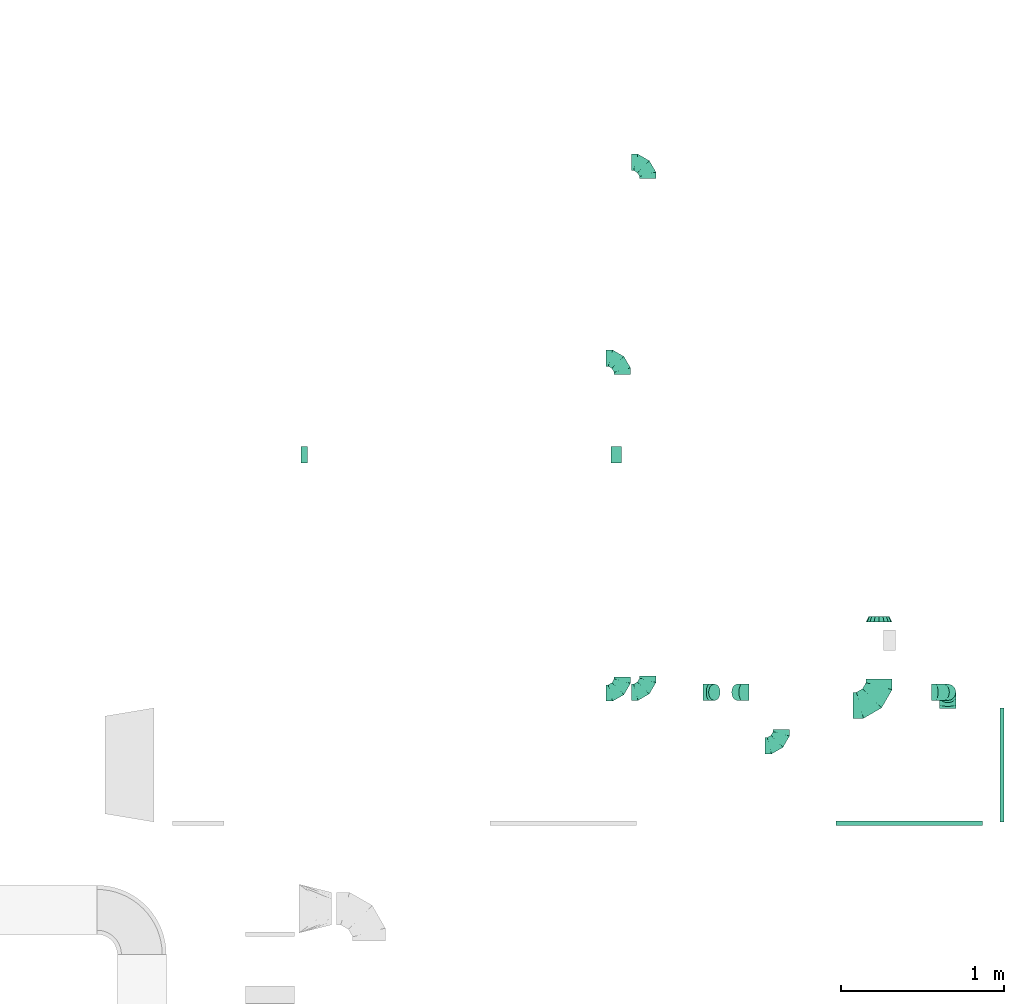
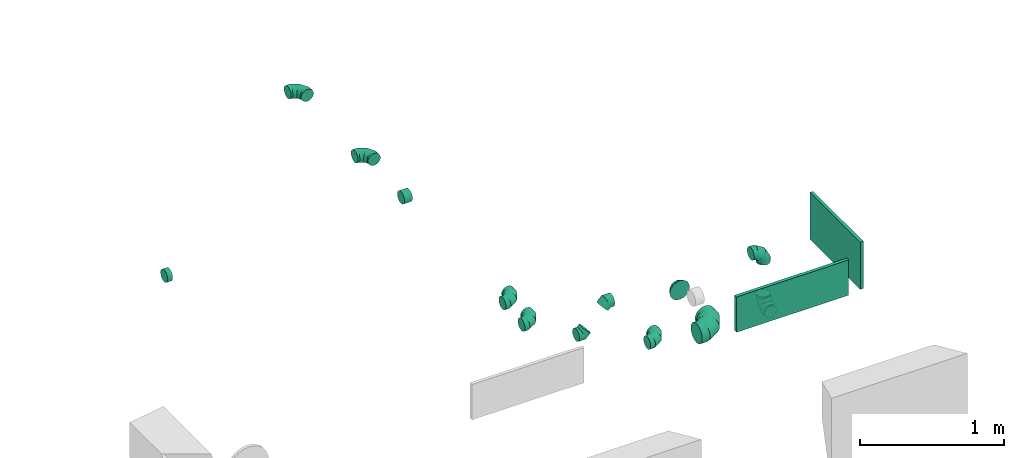
# One storey, part 54 of 62: 15 flow fittings.
"""IFC2X3 building model written with IfcOpenShell, lengths in millimetres."""

from ifc_helpers import new_model, entity, si_unit, converted_unit, derived_unit, direction, frame, origin, origin_2d_with_axis, place, context, subcontext, project, spatial, rectangle, extrude, faceted_brep, source, transform, mapped, material, type_object, type_shapes, element, save


model = new_model("IFC2X3")

# Units and contexts
model_context = context("Model", 3, precision=0.01, world=origin(), true_north=direction((6.12303176911189e-17, 1.0)))
body_context = subcontext(model_context, "Body", "Model", "MODEL_VIEW")
ifc_project = project(units=[si_unit("LENGTHUNIT", "METRE", prefix="MILLI"), si_unit("AREAUNIT", "SQUARE_METRE"), si_unit("VOLUMEUNIT", "CUBIC_METRE"), converted_unit("PLANEANGLEUNIT", "DEGREE", entity("IfcRatioMeasure", 0.0174532925199433), si_unit("PLANEANGLEUNIT", "RADIAN"), dimensions=[0, 0, 0, 0, 0, 0, 0]), si_unit("MASSUNIT", "GRAM", prefix="KILO"), derived_unit("MASSDENSITYUNIT", [(si_unit("MASSUNIT", "GRAM", prefix="KILO"), 1), (si_unit("LENGTHUNIT", "METRE"), -3)]), derived_unit("MOMENTOFINERTIAUNIT", [(si_unit("LENGTHUNIT", "METRE"), 4)]), si_unit("TIMEUNIT", "SECOND"), si_unit("FREQUENCYUNIT", "HERTZ"), si_unit("THERMODYNAMICTEMPERATUREUNIT", "DEGREE_CELSIUS"), derived_unit("THERMALTRANSMITTANCEUNIT", [(si_unit("MASSUNIT", "GRAM", prefix="KILO"), 1), (si_unit("THERMODYNAMICTEMPERATUREUNIT", "KELVIN"), -1), (si_unit("TIMEUNIT", "SECOND"), -3)]), derived_unit("VOLUMETRICFLOWRATEUNIT", [(si_unit("LENGTHUNIT", "METRE"), 3), (si_unit("TIMEUNIT", "SECOND"), -1)]), derived_unit("MASSFLOWRATEUNIT", [(si_unit("MASSUNIT", "GRAM", prefix="KILO"), 1), (si_unit("TIMEUNIT", "SECOND"), -1)]), derived_unit("ROTATIONALFREQUENCYUNIT", [(si_unit("TIMEUNIT", "SECOND"), -1)]), si_unit("ELECTRICCURRENTUNIT", "AMPERE"), si_unit("ELECTRICVOLTAGEUNIT", "VOLT"), si_unit("POWERUNIT", "WATT"), si_unit("FORCEUNIT", "NEWTON", prefix="KILO"), si_unit("ILLUMINANCEUNIT", "LUX"), si_unit("LUMINOUSFLUXUNIT", "LUMEN"), si_unit("LUMINOUSINTENSITYUNIT", "CANDELA"), derived_unit("USERDEFINED", [(si_unit("MASSUNIT", "GRAM", prefix="KILO"), -1), (si_unit("LENGTHUNIT", "METRE"), -2), (si_unit("TIMEUNIT", "SECOND"), 3), (si_unit("LUMINOUSFLUXUNIT", "LUMEN"), 1)]), derived_unit("LINEARVELOCITYUNIT", [(si_unit("LENGTHUNIT", "METRE"), 1), (si_unit("TIMEUNIT", "SECOND"), -1)]), si_unit("PRESSUREUNIT", "PASCAL"), derived_unit("USERDEFINED", [(si_unit("LENGTHUNIT", "METRE"), -2), (si_unit("MASSUNIT", "GRAM", prefix="KILO"), 1), (si_unit("TIMEUNIT", "SECOND"), -2)]), derived_unit("LINEARFORCEUNIT", [(si_unit("MASSUNIT", "GRAM", prefix="KILO"), 1), (si_unit("LENGTHUNIT", "METRE"), 1), (si_unit("TIMEUNIT", "SECOND"), -2), (si_unit("LENGTHUNIT", "METRE"), -1)]), derived_unit("PLANARFORCEUNIT", [(si_unit("MASSUNIT", "GRAM", prefix="KILO"), 1), (si_unit("LENGTHUNIT", "METRE"), 1), (si_unit("TIMEUNIT", "SECOND"), -2), (si_unit("LENGTHUNIT", "METRE"), -2)])], contexts=[model_context])

# Site, building, storey
site_placement = place(None, origin())
site = spatial("IfcSite", under=ifc_project, at=site_placement, CompositionType="ELEMENT")
building_placement = place(site_placement, origin())
building = spatial("IfcBuilding", under=site, at=building_placement, CompositionType="ELEMENT")
storey_placement = place(building_placement, frame((0.0, 0.0, 24000.0)))
storey = spatial("IfcBuildingStorey", under=building, at=storey_placement, CompositionType="ELEMENT", Elevation=24000.0)

# Flow fittings
ifc_material = material()
duct_fitting_type_1 = type_object("IfcDuctFittingType", PredefinedType="NOTDEFINED", material=ifc_material)
shared_shape_1 = source(origin(), body_context, "Body", "SweptSolid", [
    extrude(rectangle(XDim=24.9999999999999, YDim=700.0, at=origin_2d_with_axis()), frame((12.5, 0.0, -200.0)), (0.0, 0.0, 1.0), 400.0),
])
type_shapes(duct_fitting_type_1, [shared_shape_1])
flow_fitting_1_placement = place(storey_placement, frame((72981.64, 9763.98, 3550.0)))
element("IfcFlowFitting", 1, at=flow_fitting_1_placement, inside=storey, type_object=duct_fitting_type_1, material=ifc_material, context=body_context, shape_type="MappedRepresentation", body=[
    mapped(shared_shape_1, transform((0.0, 0.0, 0.0), scale=1.0)),
])
duct_fitting_type_2 = type_object("IfcDuctFittingType", PredefinedType="NOTDEFINED", material=ifc_material)
shared_shape_2 = source(origin(), body_context, "Body", "SweptSolid", [
    extrude(rectangle(XDim=26.2575337741818, YDim=900.0, at=origin_2d_with_axis()), frame((6.95, 0.0, -150.0)), (0.0, 0.0, 1.0), 300.0),
])
type_shapes(duct_fitting_type_2, [shared_shape_2])
flow_fitting_2_placement = place(storey_placement, frame((72425.78, 9413.98, 3500.0), z_axis=(0.0, 0.0, -1.0), x_axis=(0.000179481968518958, -0.999999983893111, 0.0)))
element("IfcFlowFitting", 2, at=flow_fitting_2_placement, inside=storey, type_object=duct_fitting_type_2, material=ifc_material, context=body_context, shape_type="MappedRepresentation", body=[
    mapped(shared_shape_2, transform((0.0, 0.0, 0.0), scale=1.0)),
])
duct_fitting_type_3 = type_object("IfcDuctFittingType", PredefinedType="NOTDEFINED", material=ifc_material)
shared_shape_3 = source(origin(), body_context, "Body", "Brep", [
    faceted_brep([(-160.0, 0.0, -80.0), (-160.0, -20.71, -77.27), (-160.0, -40.0, -69.28), (-160.0, -56.57, -56.57), (-160.0, -69.28, -40.0), (-160.0, -77.27, -20.71), (-160.0, -80.0, 0.0), (-160.0, -77.27, 20.71), (-160.0, -69.28, 40.0), (-160.0, -56.57, 56.57), (-160.0, -40.0, 69.28), (-160.0, -20.71, 77.27), (-160.0, 0.0, 80.0), (-160.0, 20.71, 77.27), (-160.0, 40.0, 69.28), (-160.0, 56.57, 56.57), (-160.0, 69.28, 40.0), (-160.0, 77.27, 20.71), (-160.0, 80.0, 0.0), (-160.0, 77.27, -20.71), (-160.0, 69.28, -40.0), (-160.0, 56.57, -56.57), (-160.0, 40.0, -69.28), (-160.0, 20.71, -77.27), (-122.68, 20.71, 77.27), (-127.85, 40.0, 69.28), (-117.13, 0.0, 80.0), (-132.29, 56.57, 56.57), (-137.83, 77.27, 20.71), (-138.56, 80.0, 0.0), (-135.69, 69.28, 40.0), (-135.69, 69.28, -40.0), (-132.29, 56.57, -56.57), (-137.83, 77.27, -20.71), (-122.68, 20.71, -77.27), (-117.13, 0.0, -80.0), (-127.85, 40.0, -69.28), (-111.58, -20.71, -77.27), (-106.41, -40.0, -69.28), (-101.97, -56.57, -56.57), (-98.56, -69.28, -40.0), (-96.42, -77.27, -20.71), (-95.69, -80.0, 0.0), (-96.42, -77.27, 20.71), (-98.56, -69.28, 40.0), (-101.97, -56.57, 56.57), (-106.41, -40.0, 69.28), (-111.58, -20.71, 77.27), (-58.03, 58.03, 77.27), (-72.15, 72.15, 69.28), (-42.87, 42.87, 80.0), (-84.28, 84.28, 56.57), (-93.59, 93.59, 40.0), (-99.44, 99.44, 20.71), (-101.44, 101.44, 0.0), (-99.44, 99.44, -20.71), (-93.59, 93.59, -40.0), (-84.28, 84.28, -56.57), (-58.03, 58.03, -77.27), (-42.87, 42.87, -80.0), (-72.15, 72.15, -69.28), (-27.71, 27.71, -77.27), (-13.59, 13.59, -69.28), (-1.46, 1.46, -56.57), (7.85, -7.85, -40.0), (13.7, -13.7, -20.71), (15.69, -15.69, 0.0), (13.7, -13.7, 20.71), (7.85, -7.85, 40.0), (-1.46, 1.46, 56.57), (-13.59, 13.59, 69.28), (-27.71, 27.71, 77.27), (-20.71, 122.68, 77.27), (-40.0, 127.85, 69.28), (0.0, 117.13, 80.0), (-56.57, 132.29, 56.57), (-69.28, 135.69, 40.0), (-77.27, 137.83, 20.71), (-80.0, 138.56, 0.0), (-77.27, 137.83, -20.71), (-69.28, 135.69, -40.0), (-56.57, 132.29, -56.57), (-20.71, 122.68, -77.27), (0.0, 117.13, -80.0), (-40.0, 127.85, -69.28), (20.71, 111.58, -77.27), (40.0, 106.41, -69.28), (56.57, 101.97, -56.57), (69.28, 98.56, -40.0), (77.27, 96.42, -20.71), (80.0, 95.69, 0.0), (77.27, 96.42, 20.71), (69.28, 98.56, 40.0), (56.57, 101.97, 56.57), (40.0, 106.41, 69.28), (20.71, 111.58, 77.27), (-20.71, 160.0, -77.27), (-40.0, 160.0, -69.28), (-56.57, 160.0, -56.57), (-69.28, 160.0, -40.0), (-77.27, 160.0, -20.71), (-80.0, 160.0, 0.0), (-77.27, 160.0, 20.71), (-69.28, 160.0, 40.0), (-56.57, 160.0, 56.57), (-40.0, 160.0, 69.28), (-20.71, 160.0, 77.27), (0.0, 160.0, 80.0), (20.71, 160.0, 77.27), (40.0, 160.0, 69.28), (56.57, 160.0, 56.57), (69.28, 160.0, 40.0), (77.27, 160.0, 20.71), (80.0, 160.0, 0.0), (77.27, 160.0, -20.71), (69.28, 160.0, -40.0), (56.57, 160.0, -56.57), (40.0, 160.0, -69.28), (20.71, 160.0, -77.27), (0.0, 160.0, -80.0)], [[[0, 1, 2, 3, 4, 5, 6, 7, 8, 9, 10, 11, 12, 13, 14, 15, 16, 17, 18, 19, 20, 21, 22, 23]], [[24, 25, 14, 13]], [[26, 24, 13, 12]], [[14, 25, 27, 15]], [[28, 29, 18, 17]], [[30, 28, 17, 16]], [[15, 27, 30, 16]], [[20, 31, 32, 21]], [[33, 31, 20, 19]], [[18, 29, 33, 19]], [[34, 35, 0, 23]], [[36, 34, 23, 22]], [[32, 36, 22, 21]], [[1, 0, 35, 37]], [[2, 1, 37, 38]], [[3, 2, 38, 39]], [[5, 4, 40, 41]], [[6, 5, 41, 42]], [[39, 40, 4, 3]], [[6, 42, 43, 7]], [[7, 43, 44, 8]], [[8, 44, 45, 9]], [[9, 45, 46, 10]], [[10, 46, 47, 11]], [[26, 12, 11, 47]], [[48, 49, 25, 24]], [[50, 48, 24, 26]], [[27, 25, 49, 51]], [[52, 53, 28, 30]], [[51, 52, 30, 27]], [[29, 28, 53, 54]], [[55, 56, 31, 33]], [[54, 55, 33, 29]], [[32, 31, 56, 57]], [[58, 59, 35, 34]], [[60, 58, 34, 36]], [[57, 60, 36, 32]], [[37, 35, 59, 61]], [[38, 37, 61, 62]], [[39, 38, 62, 63]], [[41, 40, 64, 65]], [[42, 41, 65, 66]], [[63, 64, 40, 39]], [[43, 42, 66, 67]], [[44, 43, 67, 68]], [[68, 69, 45, 44]], [[46, 45, 69, 70]], [[47, 46, 70, 71]], [[26, 47, 71, 50]], [[72, 73, 49, 48]], [[74, 72, 48, 50]], [[51, 49, 73, 75]], [[76, 77, 53, 52]], [[75, 76, 52, 51]], [[54, 53, 77, 78]], [[79, 80, 56, 55]], [[78, 79, 55, 54]], [[57, 56, 80, 81]], [[82, 83, 59, 58]], [[84, 82, 58, 60]], [[81, 84, 60, 57]], [[61, 59, 83, 85]], [[62, 61, 85, 86]], [[63, 62, 86, 87]], [[65, 64, 88, 89]], [[66, 65, 89, 90]], [[87, 88, 64, 63]], [[67, 66, 90, 91]], [[68, 67, 91, 92]], [[92, 93, 69, 68]], [[70, 69, 93, 94]], [[71, 70, 94, 95]], [[50, 71, 95, 74]], [[96, 97, 98, 99, 100, 101, 102, 103, 104, 105, 106, 107, 108, 109, 110, 111, 112, 113, 114, 115, 116, 117, 118, 119]], [[72, 74, 107, 106]], [[73, 72, 106, 105]], [[75, 73, 105, 104]], [[77, 76, 103, 102]], [[78, 77, 102, 101]], [[75, 104, 103, 76]], [[78, 101, 100, 79]], [[79, 100, 99, 80]], [[80, 99, 98, 81]], [[84, 97, 96, 82]], [[82, 96, 119, 83]], [[84, 81, 98, 97]], [[118, 117, 86, 85]], [[119, 118, 85, 83]], [[116, 87, 86, 117]], [[88, 115, 114, 89]], [[89, 114, 113, 90]], [[115, 88, 87, 116]], [[112, 111, 92, 91]], [[113, 112, 91, 90]], [[111, 110, 93, 92]], [[95, 94, 109, 108]], [[74, 95, 108, 107]], [[110, 109, 94, 93]]]),
])
type_shapes(duct_fitting_type_3, [shared_shape_3])
flow_fitting_3_placement = place(storey_placement, frame((72240.02, 10130.02, 2860.0)))
element("IfcFlowFitting", 3, at=flow_fitting_3_placement, inside=storey, type_object=duct_fitting_type_3, material=ifc_material, context=body_context, shape_type="MappedRepresentation", body=[
    mapped(shared_shape_3, transform((0.0, 0.0, 0.0), scale=1.0)),
])
duct_fitting_type_4 = type_object("IfcDuctFittingType", PredefinedType="NOTDEFINED", material=ifc_material)
shared_shape_4 = source(origin(), body_context, "Body", "Brep", [
    faceted_brep([(-100.0, 0.0, -50.0), (-100.0, -12.94, -48.3), (-100.0, -25.0, -43.3), (-100.0, -35.36, -35.36), (-100.0, -43.3, -25.0), (-100.0, -48.3, -12.94), (-100.0, -50.0, 0.0), (-100.0, -48.3, 12.94), (-100.0, -43.3, 25.0), (-100.0, -35.36, 35.36), (-100.0, -25.0, 43.3), (-100.0, -12.94, 48.3), (-100.0, 0.0, 50.0), (-100.0, 12.94, 48.3), (-100.0, 25.0, 43.3), (-100.0, 35.36, 35.36), (-100.0, 43.3, 25.0), (-100.0, 48.3, 12.94), (-100.0, 50.0, 0.0), (-100.0, 48.3, -12.94), (-100.0, 43.3, -25.0), (-100.0, 35.36, -35.36), (-100.0, 25.0, -43.3), (-100.0, 12.94, -48.3), (-76.67, 12.94, 48.3), (-79.9, 25.0, 43.3), (-73.21, 0.0, 50.0), (-82.68, 35.36, 35.36), (-86.15, 48.3, 12.94), (-86.6, 50.0, 0.0), (-84.81, 43.3, 25.0), (-84.81, 43.3, -25.0), (-82.68, 35.36, -35.36), (-86.15, 48.3, -12.94), (-76.67, 12.94, -48.3), (-73.21, 0.0, -50.0), (-79.9, 25.0, -43.3), (-69.74, -12.94, -48.3), (-66.51, -25.0, -43.3), (-63.73, -35.36, -35.36), (-61.6, -43.3, -25.0), (-60.26, -48.3, -12.94), (-59.81, -50.0, 0.0), (-60.26, -48.3, 12.94), (-61.6, -43.3, 25.0), (-63.73, -35.36, 35.36), (-66.51, -25.0, 43.3), (-69.74, -12.94, 48.3), (-36.27, 36.27, 48.3), (-45.1, 45.1, 43.3), (-26.79, 26.79, 50.0), (-52.68, 52.68, 35.36), (-58.49, 58.49, 25.0), (-62.15, 62.15, 12.94), (-63.4, 63.4, 0.0), (-62.15, 62.15, -12.94), (-58.49, 58.49, -25.0), (-52.68, 52.68, -35.36), (-36.27, 36.27, -48.3), (-26.79, 26.79, -50.0), (-45.1, 45.1, -43.3), (-17.32, 17.32, -48.3), (-8.49, 8.49, -43.3), (-0.91, 0.91, -35.36), (4.9, -4.9, -25.0), (8.56, -8.56, -12.94), (9.81, -9.81, 0.0), (8.56, -8.56, 12.94), (4.9, -4.9, 25.0), (-0.91, 0.91, 35.36), (-8.49, 8.49, 43.3), (-17.32, 17.32, 48.3), (-12.94, 76.67, 48.3), (-25.0, 79.9, 43.3), (0.0, 73.21, 50.0), (-35.36, 82.68, 35.36), (-43.3, 84.81, 25.0), (-48.3, 86.15, 12.94), (-50.0, 86.6, 0.0), (-48.3, 86.15, -12.94), (-43.3, 84.81, -25.0), (-35.36, 82.68, -35.36), (-12.94, 76.67, -48.3), (0.0, 73.21, -50.0), (-25.0, 79.9, -43.3), (12.94, 69.74, -48.3), (25.0, 66.51, -43.3), (35.36, 63.73, -35.36), (43.3, 61.6, -25.0), (48.3, 60.26, -12.94), (50.0, 59.81, 0.0), (48.3, 60.26, 12.94), (43.3, 61.6, 25.0), (35.36, 63.73, 35.36), (25.0, 66.51, 43.3), (12.94, 69.74, 48.3), (-12.94, 100.0, -48.3), (-25.0, 100.0, -43.3), (-35.36, 100.0, -35.36), (-43.3, 100.0, -25.0), (-48.3, 100.0, -12.94), (-50.0, 100.0, 0.0), (-48.3, 100.0, 12.94), (-43.3, 100.0, 25.0), (-35.36, 100.0, 35.36), (-25.0, 100.0, 43.3), (-12.94, 100.0, 48.3), (0.0, 100.0, 50.0), (12.94, 100.0, 48.3), (25.0, 100.0, 43.3), (35.36, 100.0, 35.36), (43.3, 100.0, 25.0), (48.3, 100.0, 12.94), (50.0, 100.0, 0.0), (48.3, 100.0, -12.94), (43.3, 100.0, -25.0), (35.36, 100.0, -35.36), (25.0, 100.0, -43.3), (12.94, 100.0, -48.3), (0.0, 100.0, -50.0)], [[[0, 1, 2, 3, 4, 5, 6, 7, 8, 9, 10, 11, 12, 13, 14, 15, 16, 17, 18, 19, 20, 21, 22, 23]], [[24, 25, 14, 13]], [[26, 24, 13, 12]], [[14, 25, 27, 15]], [[28, 29, 18, 17]], [[30, 28, 17, 16]], [[15, 27, 30, 16]], [[20, 31, 32, 21]], [[33, 31, 20, 19]], [[18, 29, 33, 19]], [[34, 35, 0, 23]], [[36, 34, 23, 22]], [[32, 36, 22, 21]], [[2, 1, 37, 38]], [[3, 2, 38, 39]], [[0, 35, 37, 1]], [[5, 4, 40, 41]], [[6, 5, 41, 42]], [[3, 39, 40, 4]], [[6, 42, 43, 7]], [[7, 43, 44, 8]], [[8, 44, 45, 9]], [[10, 46, 47, 11]], [[11, 47, 26, 12]], [[10, 9, 45, 46]], [[48, 49, 25, 24]], [[50, 48, 24, 26]], [[27, 25, 49, 51]], [[52, 53, 28, 30]], [[51, 52, 30, 27]], [[29, 28, 53, 54]], [[55, 56, 31, 33]], [[54, 55, 33, 29]], [[57, 32, 31, 56]], [[58, 59, 35, 34]], [[60, 58, 34, 36]], [[57, 60, 36, 32]], [[37, 35, 59, 61]], [[38, 37, 61, 62]], [[39, 38, 62, 63]], [[41, 40, 64, 65]], [[42, 41, 65, 66]], [[63, 64, 40, 39]], [[43, 42, 66, 67]], [[44, 43, 67, 68]], [[68, 69, 45, 44]], [[46, 45, 69, 70]], [[47, 46, 70, 71]], [[26, 47, 71, 50]], [[72, 73, 49, 48]], [[74, 72, 48, 50]], [[51, 49, 73, 75]], [[76, 77, 53, 52]], [[75, 76, 52, 51]], [[54, 53, 77, 78]], [[79, 80, 56, 55]], [[78, 79, 55, 54]], [[81, 57, 56, 80]], [[82, 83, 59, 58]], [[84, 82, 58, 60]], [[81, 84, 60, 57]], [[61, 59, 83, 85]], [[62, 61, 85, 86]], [[63, 62, 86, 87]], [[65, 64, 88, 89]], [[66, 65, 89, 90]], [[87, 88, 64, 63]], [[67, 66, 90, 91]], [[68, 67, 91, 92]], [[92, 93, 69, 68]], [[70, 69, 93, 94]], [[71, 70, 94, 95]], [[50, 71, 95, 74]], [[96, 97, 98, 99, 100, 101, 102, 103, 104, 105, 106, 107, 108, 109, 110, 111, 112, 113, 114, 115, 116, 117, 118, 119]], [[72, 74, 107, 106]], [[73, 72, 106, 105]], [[75, 73, 105, 104]], [[77, 76, 103, 102]], [[78, 77, 102, 101]], [[75, 104, 103, 76]], [[78, 101, 100, 79]], [[79, 100, 99, 80]], [[80, 99, 98, 81]], [[96, 119, 83, 82]], [[97, 96, 82, 84]], [[84, 81, 98, 97]], [[83, 119, 118, 85]], [[85, 118, 117, 86]], [[86, 117, 116, 87]], [[88, 115, 114, 89]], [[89, 114, 113, 90]], [[87, 116, 115, 88]], [[91, 90, 113, 112]], [[92, 91, 112, 111]], [[93, 92, 111, 110]], [[95, 94, 109, 108]], [[74, 95, 108, 107]], [[110, 109, 94, 93]]]),
])
type_shapes(duct_fitting_type_4, [shared_shape_4])
flow_fitting_4_placement = place(storey_placement, frame((70820.86, 13461.26, 3360.0), z_axis=(0.0, 0.0, 1.0), x_axis=(0.0, 1.0, 0.0)))
element("IfcFlowFitting", 4, at=flow_fitting_4_placement, inside=storey, type_object=duct_fitting_type_4, material=ifc_material, context=body_context, shape_type="MappedRepresentation", body=[
    mapped(shared_shape_4, transform((0.0, 0.0, 0.0), scale=1.0)),
])
flow_fitting_5_placement = place(storey_placement, frame((70664.88, 10205.08, 3600.0)))
element("IfcFlowFitting", 5, at=flow_fitting_5_placement, inside=storey, type_object=duct_fitting_type_4, material=ifc_material, context=body_context, shape_type="MappedRepresentation", body=[
    mapped(shared_shape_4, transform((0.0, 0.0, 0.0), scale=1.0)),
])
flow_fitting_6_placement = place(storey_placement, frame((70664.88, 12260.08, 3600.0), z_axis=(0.0, 0.0, 1.0), x_axis=(0.0, 1.0, 0.0)))
element("IfcFlowFitting", 6, at=flow_fitting_6_placement, inside=storey, type_object=duct_fitting_type_4, material=ifc_material, context=body_context, shape_type="MappedRepresentation", body=[
    mapped(shared_shape_4, transform((0.0, 0.0, 0.0), scale=1.0)),
])
flow_fitting_7_placement = place(storey_placement, frame((70820.86, 10209.98, 3360.0)))
element("IfcFlowFitting", 7, at=flow_fitting_7_placement, inside=storey, type_object=duct_fitting_type_4, material=ifc_material, context=body_context, shape_type="MappedRepresentation", body=[
    mapped(shared_shape_4, transform((0.0, 0.0, 0.0), scale=1.0)),
])
flow_fitting_8_placement = place(storey_placement, frame((72661.37, 10209.97, 2850.0), z_axis=(1.0, 0.0, 0.0), x_axis=(0.0, 1.0, 0.0)))
element("IfcFlowFitting", 8, at=flow_fitting_8_placement, inside=storey, type_object=duct_fitting_type_4, material=ifc_material, context=body_context, shape_type="MappedRepresentation", body=[
    mapped(shared_shape_4, transform((0.0, 0.0, 0.0), scale=1.0)),
])
flow_fitting_9_placement = place(storey_placement, frame((71640.23, 9881.53, 3120.0)))
element("IfcFlowFitting", 9, at=flow_fitting_9_placement, inside=storey, type_object=duct_fitting_type_4, material=ifc_material, context=body_context, shape_type="MappedRepresentation", body=[
    mapped(shared_shape_4, transform((0.0, 0.0, 0.0), scale=1.0)),
])
flow_fitting_10_placement = place(storey_placement, frame((72661.37, 10209.97, 3320.0), z_axis=(0.0, -1.0, 0.0), x_axis=(0.0, 0.0, 1.0)))
element("IfcFlowFitting", 10, at=flow_fitting_10_placement, inside=storey, type_object=duct_fitting_type_4, material=ifc_material, context=body_context, shape_type="MappedRepresentation", body=[
    mapped(shared_shape_4, transform((0.0, 0.0, 0.0), scale=1.0)),
])
duct_fitting_type_5 = type_object("IfcDuctFittingType", PredefinedType="NOTDEFINED", material=ifc_material)
shared_shape_5 = source(origin(), body_context, "Body", "Brep", [
    faceted_brep([(35.0, -57.74, 23.92), (35.0, -60.12, 11.96), (35.0, -62.5, 0.0), (35.0, -60.12, -11.96), (35.0, -57.74, -23.92), (35.0, -50.97, -34.06), (35.0, -44.19, -44.19), (35.0, -34.06, -50.97), (35.0, -23.92, -57.74), (35.0, -11.96, -60.12), (35.0, 0.0, -62.5), (35.0, 11.96, -60.12), (35.0, 23.92, -57.74), (35.0, 34.06, -50.97), (35.0, 44.19, -44.19), (35.0, 50.97, -34.06), (35.0, 57.74, -23.92), (35.0, 60.12, -11.96), (35.0, 62.5, 0.0), (35.0, 60.12, 11.96), (35.0, 57.74, 23.92), (35.0, 50.97, 34.06), (35.0, 44.19, 44.19), (35.0, 34.06, 50.97), (35.0, 23.92, 57.74), (35.0, 11.96, 60.12), (35.0, 0.0, 62.5), (35.0, -11.96, 60.12), (35.0, -23.92, 57.74), (35.0, -34.06, 50.97), (35.0, -44.19, 44.19), (35.0, -50.97, 34.06), (0.0, -80.0, 0.0), (0.0, -77.45, 12.81), (0.0, -73.91, 30.61), (0.0, -65.24, 43.59), (0.0, -56.57, 56.57), (0.0, -43.59, 65.24), (0.0, -30.61, 73.91), (0.0, -12.81, 77.45), (0.0, 0.0, 80.0), (0.0, 12.81, 77.45), (0.0, 30.61, 73.91), (0.0, 43.59, 65.24), (0.0, 56.57, 56.57), (0.0, 65.24, 43.59), (0.0, 73.91, 30.61), (0.0, 77.45, 12.81), (0.0, 80.0, 0.0), (0.0, 77.45, -12.81), (0.0, 73.91, -30.61), (0.0, 65.24, -43.59), (0.0, 56.57, -56.57), (0.0, 43.59, -65.24), (0.0, 30.61, -73.91), (0.0, 12.81, -77.45), (0.0, 0.0, -80.0), (0.0, -12.81, -77.45), (0.0, -30.61, -73.91), (0.0, -43.59, -65.24), (0.0, -56.57, -56.57), (0.0, -65.24, -43.59), (0.0, -73.91, -30.61), (0.0, -77.45, -12.81)], [[[0, 1, 2, 3, 4, 5, 6, 7, 8, 9, 10, 11, 12, 13, 14, 15, 16, 17, 18, 19, 20, 21, 22, 23, 24, 25, 26, 27, 28, 29, 30, 31]], [[32, 33, 34, 35, 36, 37, 38, 39, 40, 41, 42, 43, 44, 45, 46, 47, 48, 49, 50, 51, 52, 53, 54, 55, 56, 57, 58, 59, 60, 61, 62, 63]], [[24, 23, 22, 44, 43, 42]], [[20, 46, 45, 44, 22, 21]], [[42, 41, 40, 26, 25, 24]], [[47, 46, 20, 19, 18, 48]], [[0, 31, 30, 36, 35, 34]], [[28, 38, 37, 36, 30, 29]], [[34, 33, 32, 2, 1, 0]], [[39, 38, 28, 27, 26, 40]], [[8, 7, 6, 60, 59, 58]], [[4, 62, 61, 60, 6, 5]], [[58, 57, 56, 10, 9, 8]], [[63, 62, 4, 3, 2, 32]], [[16, 15, 14, 52, 51, 50]], [[12, 54, 53, 52, 14, 13]], [[50, 49, 48, 18, 17, 16]], [[55, 54, 12, 11, 10, 56]]]),
])
type_shapes(duct_fitting_type_5, [shared_shape_5])
flow_fitting_11_placement = place(storey_placement, frame((72240.02, 10640.99, 2860.0), z_axis=(0.0, 0.0, 1.0), x_axis=(0.0, 1.0, 0.0)))
element("IfcFlowFitting", 11, at=flow_fitting_11_placement, inside=storey, type_object=duct_fitting_type_5, material=ifc_material, context=body_context, shape_type="MappedRepresentation", body=[
    mapped(shared_shape_5, transform((0.0, 0.0, 0.0), scale=1.0)),
])
duct_fitting_type_6 = type_object("IfcDuctFittingType", PredefinedType="NOTDEFINED", material=ifc_material)
shared_shape_6 = source(origin(), body_context, "Body", "Brep", [
    faceted_brep([(-41.42, 0.0, -50.0), (-41.42, -12.94, -48.3), (-41.42, -25.0, -43.3), (-41.42, -35.36, -35.36), (-41.42, -43.3, -25.0), (-41.42, -48.3, -12.94), (-41.42, -50.0, 0.0), (-41.42, -48.3, 12.94), (-41.42, -43.3, 25.0), (-41.42, -35.36, 35.36), (-41.42, -25.0, 43.3), (-41.42, -12.94, 48.3), (-41.42, 0.0, 50.0), (-41.42, 12.94, 48.3), (-41.42, 25.0, 43.3), (-41.42, 35.36, 35.36), (-41.42, 43.3, 25.0), (-41.42, 48.3, 12.94), (-41.42, 50.0, 0.0), (-41.42, 48.3, -12.94), (-41.42, 43.3, -25.0), (-41.42, 35.36, -35.36), (-41.42, 25.0, -43.3), (-41.42, 12.94, -48.3), (-5.36, 12.94, 48.3), (-10.36, 25.0, 43.3), (0.0, 0.0, 50.0), (-14.64, 35.36, 35.36), (-20.0, 48.3, 12.94), (-20.71, 50.0, 0.0), (-17.94, 43.3, 25.0), (-17.94, 43.3, -25.0), (-14.64, 35.36, -35.36), (-20.0, 48.3, -12.94), (-5.36, 12.94, -48.3), (0.0, 0.0, -50.0), (-10.36, 25.0, -43.3), (5.36, -12.94, -48.3), (10.36, -25.0, -43.3), (14.64, -35.36, -35.36), (17.94, -43.3, -25.0), (20.0, -48.3, -12.94), (20.71, -50.0, 0.0), (20.0, -48.3, 12.94), (17.94, -43.3, 25.0), (14.64, -35.36, 35.36), (10.36, -25.0, 43.3), (5.36, -12.94, 48.3), (29.29, 29.29, 50.0), (20.14, 38.44, 48.3), (11.61, 46.97, 43.3), (4.29, 54.29, 35.36), (-1.33, 59.91, 25.0), (-4.86, 63.44, 12.94), (-6.07, 64.64, 0.0), (-4.86, 63.44, -12.94), (-1.33, 59.91, -25.0), (4.29, 54.29, -35.36), (11.61, 46.97, -43.3), (20.14, 38.44, -48.3), (29.29, 29.29, -50.0), (38.44, 20.14, -48.3), (46.97, 11.61, -43.3), (54.29, 4.29, -35.36), (59.91, -1.33, -25.0), (63.44, -4.86, -12.94), (64.64, -6.07, 0.0), (63.44, -4.86, 12.94), (59.91, -1.33, 25.0), (54.29, 4.29, 35.36), (46.97, 11.61, 43.3), (38.44, 20.14, 48.3)], [[[0, 1, 2, 3, 4, 5, 6, 7, 8, 9, 10, 11, 12, 13, 14, 15, 16, 17, 18, 19, 20, 21, 22, 23]], [[24, 25, 14, 13]], [[26, 24, 13, 12]], [[14, 25, 27, 15]], [[28, 29, 18, 17]], [[30, 28, 17, 16]], [[16, 15, 27, 30]], [[20, 31, 32, 21]], [[33, 31, 20, 19]], [[18, 29, 33, 19]], [[34, 35, 0, 23]], [[36, 34, 23, 22]], [[32, 36, 22, 21]], [[1, 0, 35, 37]], [[2, 1, 37, 38]], [[38, 39, 3, 2]], [[5, 4, 40, 41]], [[6, 5, 41, 42]], [[39, 40, 4, 3]], [[6, 42, 43, 7]], [[7, 43, 44, 8]], [[8, 44, 45, 9]], [[9, 45, 46, 10]], [[10, 46, 47, 11]], [[26, 12, 11, 47]], [[24, 26, 48, 49]], [[25, 24, 49, 50]], [[27, 25, 50, 51]], [[28, 30, 52, 53]], [[29, 28, 53, 54]], [[27, 51, 52, 30]], [[29, 54, 55, 33]], [[33, 55, 56, 31]], [[31, 56, 57, 32]], [[36, 58, 59, 34]], [[34, 59, 60, 35]], [[36, 32, 57, 58]], [[61, 62, 38, 37]], [[60, 61, 37, 35]], [[63, 39, 38, 62]], [[40, 64, 65, 41]], [[41, 65, 66, 42]], [[64, 40, 39, 63]], [[43, 42, 66, 67]], [[44, 43, 67, 68]], [[68, 69, 45, 44]], [[47, 46, 70, 71]], [[26, 47, 71, 48]], [[69, 70, 46, 45]], [[59, 58, 57, 56, 55, 54, 53, 52, 51, 50, 49, 48, 71, 70, 69, 68, 67, 66, 65, 64, 63, 62, 61, 60]]]),
])
type_shapes(duct_fitting_type_6, [shared_shape_6])
for number, where, z_axis, x_axis in (
    (12, (71200.5, 10209.97, 3120.0), (0.0, -1.0, 0.0), (1.0, 0.0, 0.0)),
    (13, (71400.5, 10209.97, 3320.0), (0.0, 1.0, 0.0), (0.707106781186483, 0.0, 0.707106781186613)),
):
    element("IfcFlowFitting", number, at=place(storey_placement, frame(where, z_axis=z_axis, x_axis=x_axis)), inside=storey, type_object=duct_fitting_type_6, material=ifc_material, context=body_context, shape_type="MappedRepresentation", body=[
        mapped(shared_shape_6, transform((0.0, 0.0, 0.0), scale=1.0)),
    ])
duct_fitting_type_7 = type_object("IfcDuctFittingType", PredefinedType="NOTDEFINED", material=ifc_material)
shared_shape_7 = source(origin(), body_context, "Body", "Brep", [
    faceted_brep([(20.0, 0.0, -50.0), (20.0, 12.94, -48.3), (20.0, 25.0, -43.3), (20.0, 35.36, -35.36), (20.0, 43.3, -25.0), (20.0, 48.3, -12.94), (20.0, 50.0, 0.0), (20.0, 48.3, 12.94), (20.0, 43.3, 25.0), (20.0, 35.36, 35.36), (20.0, 25.0, 43.3), (20.0, 12.94, 48.3), (20.0, 0.0, 50.0), (20.0, -12.94, 48.3), (20.0, -25.0, 43.3), (20.0, -35.36, 35.36), (20.0, -43.3, 25.0), (20.0, -48.3, 12.94), (20.0, -50.0, 0.0), (20.0, -48.3, -12.94), (20.0, -43.3, -25.0), (20.0, -35.36, -35.36), (20.0, -25.0, -43.3), (20.0, -12.94, -48.3), (0.0, 0.0, 50.0), (-43.9, 0.0, 50.0), (-43.9, -12.94, 48.3), (0.0, -12.94, 48.3), (-43.9, -25.0, 43.3), (0.0, -25.0, 43.3), (0.0, -35.36, 35.36), (-43.9, -35.36, 35.36), (0.0, -43.3, 25.0), (-43.9, -43.3, 25.0), (-43.9, -48.3, 12.94), (0.0, -48.3, 12.94), (-43.9, -50.0, 0.0), (0.0, -50.0, 0.0), (-43.9, -48.3, -12.94), (0.0, -48.3, -12.94), (-43.9, -43.3, -25.0), (0.0, -43.3, -25.0), (0.0, -35.36, -35.36), (-43.9, -35.36, -35.36), (0.0, -25.0, -43.3), (-43.9, -25.0, -43.3), (-43.9, -12.94, -48.3), (0.0, -12.94, -48.3), (-43.9, 0.0, -50.0), (0.0, 0.0, -50.0), (-43.9, 12.94, -48.3), (0.0, 12.94, -48.3), (-43.9, 25.0, -43.3), (0.0, 25.0, -43.3), (0.0, 35.36, -35.36), (-43.9, 35.36, -35.36), (0.0, 43.3, -25.0), (-43.9, 43.3, -25.0), (-43.9, 48.3, -12.94), (0.0, 48.3, -12.94), (-43.9, 50.0, 0.0), (0.0, 50.0, 0.0), (-43.9, 48.3, 12.94), (0.0, 48.3, 12.94), (-43.9, 43.3, 25.0), (0.0, 43.3, 25.0), (0.0, 35.36, 35.36), (-43.9, 35.36, 35.36), (0.0, 25.0, 43.3), (-43.9, 25.0, 43.3), (-43.9, 12.94, 48.3), (0.0, 12.94, 48.3)], [[[0, 1, 2, 3, 4, 5, 6, 7, 8, 9, 10, 11, 12, 13, 14, 15, 16, 17, 18, 19, 20, 21, 22, 23]], [[13, 12, 24, 25, 26, 27]], [[14, 13, 27, 26, 28, 29]], [[30, 15, 14, 29, 28, 31]], [[17, 16, 32, 33, 34, 35]], [[18, 17, 35, 34, 36, 37]], [[32, 16, 15, 30, 31, 33]], [[19, 18, 37, 36, 38, 39]], [[20, 19, 39, 38, 40, 41]], [[42, 21, 20, 41, 40, 43]], [[23, 22, 44, 45, 46, 47]], [[0, 23, 47, 46, 48, 49]], [[44, 22, 21, 42, 43, 45]], [[1, 0, 49, 48, 50, 51]], [[2, 1, 51, 50, 52, 53]], [[54, 3, 2, 53, 52, 55]], [[5, 4, 56, 57, 58, 59]], [[6, 5, 59, 58, 60, 61]], [[56, 4, 3, 54, 55, 57]], [[7, 6, 61, 60, 62, 63]], [[8, 7, 63, 62, 64, 65]], [[66, 9, 8, 65, 64, 67]], [[11, 10, 68, 69, 70, 71]], [[12, 11, 71, 70, 25, 24]], [[68, 10, 9, 66, 67, 69]], [[46, 45, 43, 40, 38, 36, 34, 33, 31, 28, 26, 25, 70, 69, 67, 64, 62, 60, 58, 57, 55, 52, 50, 48]]]),
])
type_shapes(duct_fitting_type_7, [shared_shape_7])
flow_fitting_12_placement = place(storey_placement, frame((70614.88, 11667.58, 3600.0), z_axis=(0.0, 0.0, -1.0), x_axis=(-1.0, 0.0, 0.0)))
element("IfcFlowFitting", 14, at=flow_fitting_12_placement, inside=storey, type_object=duct_fitting_type_7, material=ifc_material, context=body_context, shape_type="MappedRepresentation", body=[
    mapped(shared_shape_7, transform((0.0, 0.0, 0.0), scale=1.0)),
])
duct_fitting_type_8 = type_object("IfcDuctFittingType", PredefinedType="NOTDEFINED", material=ifc_material)
shared_shape_8 = source(origin(), body_context, "Body", "Brep", [
    faceted_brep([(20.0, 12.94, -48.3), (20.0, 25.0, -43.3), (20.0, 35.36, -35.36), (20.0, 43.3, -25.0), (20.0, 48.3, -12.94), (20.0, 50.0, 0.0), (20.0, 48.3, 12.94), (20.0, 43.3, 25.0), (20.0, 35.36, 35.36), (20.0, 25.0, 43.3), (20.0, 12.94, 48.3), (20.0, 0.0, 50.0), (20.0, -12.94, 48.3), (20.0, -25.0, 43.3), (20.0, -35.36, 35.36), (20.0, -43.3, 25.0), (20.0, -48.3, 12.94), (20.0, -50.0, 0.0), (20.0, -48.3, -12.94), (20.0, -43.3, -25.0), (20.0, -35.36, -35.36), (20.0, -25.0, -43.3), (20.0, -12.94, -48.3), (20.0, 0.0, -50.0), (0.0, 0.0, 50.0), (0.0, 12.94, 48.3), (-19.49, 12.94, 48.3), (-19.49, 0.0, 50.0), (0.0, 25.0, 43.3), (-19.49, 25.0, 43.3), (0.0, 35.36, 35.36), (-19.49, 35.36, 35.36), (0.0, 43.3, 25.0), (0.0, 48.3, 12.94), (-19.49, 48.3, 12.94), (-19.49, 43.3, 25.0), (0.0, 50.0, 0.0), (-19.49, 50.0, 0.0), (0.0, 48.3, -12.94), (-19.49, 48.3, -12.94), (0.0, 43.3, -25.0), (-19.49, 43.3, -25.0), (0.0, 35.36, -35.36), (-19.49, 35.36, -35.36), (0.0, 25.0, -43.3), (0.0, 12.94, -48.3), (-19.49, 12.94, -48.3), (-19.49, 25.0, -43.3), (0.0, 0.0, -50.0), (-19.49, 0.0, -50.0), (0.0, -12.94, -48.3), (-19.49, -12.94, -48.3), (0.0, -25.0, -43.3), (-19.49, -25.0, -43.3), (0.0, -35.36, -35.36), (-19.49, -35.36, -35.36), (0.0, -43.3, -25.0), (0.0, -48.3, -12.94), (-19.49, -48.3, -12.94), (-19.49, -43.3, -25.0), (0.0, -50.0, 0.0), (-19.49, -50.0, 0.0), (0.0, -48.3, 12.94), (-19.49, -48.3, 12.94), (0.0, -43.3, 25.0), (-19.49, -43.3, 25.0), (0.0, -35.36, 35.36), (-19.49, -35.36, 35.36), (0.0, -25.0, 43.3), (0.0, -12.94, 48.3), (-19.49, -12.94, 48.3), (-19.49, -25.0, 43.3)], [[[0, 1, 2, 3, 4, 5, 6, 7, 8, 9, 10, 11, 12, 13, 14, 15, 16, 17, 18, 19, 20, 21, 22, 23]], [[24, 11, 10, 25, 26, 27]], [[25, 10, 9, 28, 29, 26]], [[28, 9, 8, 30, 31, 29]], [[32, 7, 6, 33, 34, 35]], [[33, 6, 5, 36, 37, 34]], [[30, 8, 7, 32, 35, 31]], [[36, 5, 4, 38, 39, 37]], [[38, 4, 3, 40, 41, 39]], [[40, 3, 2, 42, 43, 41]], [[44, 1, 0, 45, 46, 47]], [[45, 0, 23, 48, 49, 46]], [[42, 2, 1, 44, 47, 43]], [[48, 23, 22, 50, 51, 49]], [[50, 22, 21, 52, 53, 51]], [[52, 21, 20, 54, 55, 53]], [[56, 19, 18, 57, 58, 59]], [[57, 18, 17, 60, 61, 58]], [[54, 20, 19, 56, 59, 55]], [[60, 17, 16, 62, 63, 61]], [[62, 16, 15, 64, 65, 63]], [[64, 15, 14, 66, 67, 65]], [[68, 13, 12, 69, 70, 71]], [[69, 12, 11, 24, 27, 70]], [[66, 14, 13, 68, 71, 67]], [[49, 51, 53, 55, 59, 58, 61, 63, 65, 67, 71, 70, 27, 26, 29, 31, 35, 34, 37, 39, 41, 43, 47, 46]]]),
])
type_shapes(duct_fitting_type_8, [shared_shape_8])
flow_fitting_13_placement = place(storey_placement, frame((68713.63, 11667.58, 3600.0), z_axis=(0.0, -1.0, 0.0), x_axis=(1.0, 0.0, 0.0)))
element("IfcFlowFitting", 15, at=flow_fitting_13_placement, inside=storey, type_object=duct_fitting_type_8, material=ifc_material, context=body_context, shape_type="MappedRepresentation", body=[
    mapped(shared_shape_8, transform((0.0, 0.0, 0.0), scale=1.0)),
])

save(model, "model.ifc")
